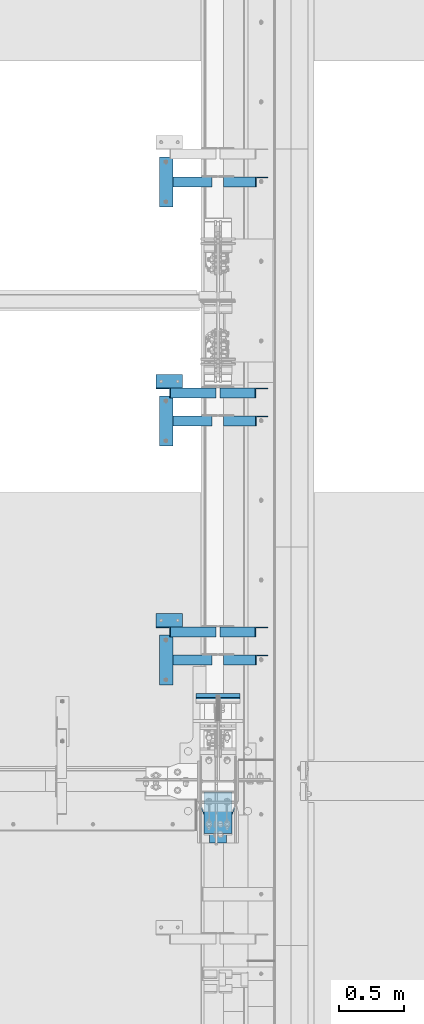
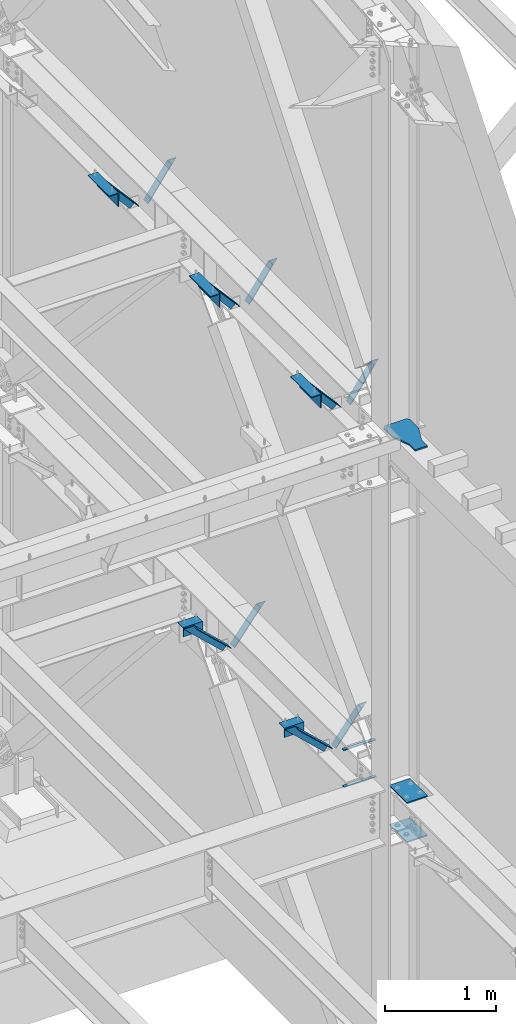
# One storey, part 844 of 1179: 10 beams, 10 members, 18 elements without a shape of their own.
"""IFC2X3 building model written with IfcOpenShell, lengths in millimetres."""

from ifc_helpers import new_model, si_unit, frame, origin_with_axes, place, context, subcontext, project, spatial, faceted_brep, material, type_object, element, aggregate, save


model = new_model("IFC2X3")

# Units and contexts
model_context = context("Model", 3, precision=1e-05, world=origin_with_axes())
body_context = subcontext(model_context, "Body", "Model", "MODEL_VIEW")
ifc_project = project(units=[si_unit("LENGTHUNIT", "METRE", prefix="MILLI"), si_unit("AREAUNIT", "SQUARE_METRE"), si_unit("VOLUMEUNIT", "CUBIC_METRE"), si_unit("MASSUNIT", "GRAM", prefix="KILO"), si_unit("TIMEUNIT", "SECOND"), si_unit("PLANEANGLEUNIT", "RADIAN"), si_unit("SOLIDANGLEUNIT", "STERADIAN"), si_unit("THERMODYNAMICTEMPERATUREUNIT", "DEGREE_CELSIUS"), si_unit("LUMINOUSINTENSITYUNIT", "LUMEN")], contexts=[model_context])

# Site, building, storey
site_placement = place(None, origin_with_axes())
site = spatial("IfcSite", under=ifc_project, at=site_placement, CompositionType="ELEMENT")
building_placement = place(site_placement, origin_with_axes())
building = spatial("IfcBuilding", under=site, at=building_placement, Name="Undefined", CompositionType="ELEMENT")
storey_placement = place(building_placement, origin_with_axes())
storey = spatial("IfcBuildingStorey", under=building, at=storey_placement, Name="Undefined", CompositionType="ELEMENT", Elevation=0.0)

# Assembly, beam
assembly_1_placement = place(storey_placement, origin_with_axes())
assembly_1 = element("IfcElementAssembly", 1, at=assembly_1_placement, inside=storey, Name="ANGLE", AssemblyPlace="NOTDEFINED", PredefinedType="RIGID_FRAME")
ifc_material_1 = material(Name="STEEL/A36")
beam_type_1 = type_object("IfcBeamType", Name="L6X4X5/16", PredefinedType="NOTDEFINED")
beam_1_placement = place(assembly_1_placement, frame((23910.8411671176, 31444.5838232686, 7937.5), z_axis=(0.0, 0.0, -1.0), x_axis=(0.0, 1.0, 0.0)))
beam_1 = element("IfcBeam", 2, at=beam_1_placement, type_object=beam_type_1, material=ifc_material_1, Name="ANGLE", ObjectType="L6X4X5/16", context=body_context, shape_type="Brep", body=[
    faceted_brep([(0.0, 50.8000000000029, -76.1999999999998), (0.0, 50.8000000000029, 76.1999999999998), (381.0, 50.7999999999993, 76.1999999999998), (381.0, 50.7999999999993, -76.1999999999998), (0.0, 42.8624999999993, 76.1999999999998), (381.0, 42.8624999999993, 76.1999999999998), (0.0, 42.8624999999993, -68.2624999999998), (381.0, 42.8624999999993, -68.2624999999998), (0.0, -50.7999999999993, -68.2624999999998), (381.0, -50.7999999999993, -68.2624999999998), (0.0, -50.8000000000029, -76.1999999999998), (381.0, -50.7999999999993, -76.1999999999998)], [[[0, 1, 2, 3]], [[1, 4, 5, 2]], [[4, 6, 7, 5]], [[6, 8, 9, 7]], [[8, 10, 11, 9]], [[10, 0, 3, 11]], [[5, 7, 9, 11, 3, 2]], [[10, 8, 6, 4, 1, 0]]]),
])
aggregate(assembly_1, [beam_1])

assembly_2_placement = place(storey_placement, origin_with_axes())
assembly_2 = element("IfcElementAssembly", 3, at=assembly_2_placement, inside=storey, Name="ANGLE", AssemblyPlace="NOTDEFINED", PredefinedType="RIGID_FRAME")
beam_2_placement = place(assembly_2_placement, frame((23910.8411671176, 29615.7838232686, 7937.5), z_axis=(0.0, 0.0, -1.0), x_axis=(0.0, 1.0, 0.0)))
beam_2 = element("IfcBeam", 4, at=beam_2_placement, type_object=beam_type_1, material=ifc_material_1, Name="ANGLE", ObjectType="L6X4X5/16", context=body_context, shape_type="Brep", body=[
    faceted_brep([(0.0, 50.8000000000029, -76.1999999999998), (0.0, 50.8000000000029, 76.1999999999998), (381.0, 50.7999999999993, 76.1999999999998), (381.0, 50.7999999999993, -76.1999999999998), (0.0, 42.8624999999993, 76.1999999999998), (381.0, 42.8624999999993, 76.1999999999998), (0.0, 42.8624999999993, -68.2624999999998), (381.0, 42.8624999999993, -68.2624999999998), (0.0, -50.7999999999993, -68.2624999999998), (381.0, -50.7999999999993, -68.2624999999998), (0.0, -50.8000000000029, -76.1999999999998), (381.0, -50.7999999999993, -76.1999999999998)], [[[0, 1, 2, 3]], [[1, 4, 5, 2]], [[4, 6, 7, 5]], [[6, 8, 9, 7]], [[8, 10, 11, 9]], [[10, 0, 3, 11]], [[5, 7, 9, 11, 3, 2]], [[10, 8, 6, 4, 1, 0]]]),
])
aggregate(assembly_2, [beam_2])

assembly_3_placement = place(storey_placement, origin_with_axes())
assembly_3 = element("IfcElementAssembly", 5, at=assembly_3_placement, inside=storey, Name="ANGLE", AssemblyPlace="NOTDEFINED", PredefinedType="RIGID_FRAME")
beam_3_placement = place(assembly_3_placement, frame((23910.8411671176, 27786.9838232686, 7937.5), z_axis=(0.0, 0.0, -1.0), x_axis=(0.0, 1.0, 0.0)))
beam_3 = element("IfcBeam", 6, at=beam_3_placement, type_object=beam_type_1, material=ifc_material_1, Name="ANGLE", ObjectType="L6X4X5/16", context=body_context, shape_type="Brep", body=[
    faceted_brep([(0.0, 50.8000000000029, -76.1999999999998), (0.0, 50.8000000000029, 76.1999999999998), (381.0, 50.7999999999993, 76.1999999999998), (381.0, 50.7999999999993, -76.1999999999998), (0.0, 42.8624999999993, 76.1999999999998), (381.0, 42.8624999999993, 76.1999999999998), (0.0, 42.8624999999993, -68.2624999999998), (381.0, 42.8624999999993, -68.2624999999998), (0.0, -50.7999999999993, -68.2624999999998), (381.0, -50.7999999999993, -68.2624999999998), (0.0, -50.8000000000029, -76.1999999999998), (381.0, -50.7999999999993, -76.1999999999998)], [[[0, 1, 2, 3]], [[1, 4, 5, 2]], [[4, 6, 7, 5]], [[6, 8, 9, 7]], [[8, 10, 11, 9]], [[10, 0, 3, 11]], [[5, 7, 9, 11, 3, 2]], [[10, 8, 6, 4, 1, 0]]]),
])
aggregate(assembly_3, [beam_3])

# Assembly, member
assembly_4_placement = place(storey_placement, origin_with_axes())
assembly_4 = element("IfcElementAssembly", 7, at=assembly_4_placement, inside=storey, Name="ANGLE", AssemblyPlace="NOTDEFINED", PredefinedType="RIGID_FRAME")
member_type = type_object("IfcMemberType", Name="L3X3X1/4", PredefinedType="NOTDEFINED")
member_1_placement = place(assembly_4_placement, frame((23812.1988269993, 31635.0838232686, 8126.5003839724), z_axis=(0.0, -1.0, 0.0), x_axis=(0.658094639765331, 0.0, -0.752935219731512)))
member_1 = element("IfcMember", 8, at=member_1_placement, type_object=member_type, material=ifc_material_1, Name="ANGLE", ObjectType="L3X3X1/4", context=body_context, shape_type="Brep", body=[
    faceted_brep([(183.619860552442, 38.1000000000859, -38.0999999999985), (183.619860784022, 38.1000000000822, 38.0999999999985), (639.062001231554, 38.1000000003442, 38.0999999999985), (639.062001231554, 38.1000000003442, -38.0999999999985), (190.88498399944, 31.7500000000909, 38.0999999999985), (639.062001231561, 31.7500000003529, 38.0999999999985), (190.884983787158, 31.7500000000873, -31.75), (639.062001231561, 31.7500000003529, -31.75), (270.801339156757, -38.0999999998203, -31.75), (639.062001231592, -38.0999999996056, -31.75), (270.801339137461, -38.0999999998203, -38.0999999999985), (639.062001231592, -38.0999999996056, -38.0999999999985)], [[[0, 1, 2, 3]], [[1, 4, 5, 2]], [[4, 6, 7, 5]], [[6, 8, 9, 7]], [[8, 10, 11, 9]], [[10, 0, 3, 11]], [[5, 7, 9, 11, 3, 2]], [[10, 8, 6, 4, 1, 0]]]),
])
aggregate(assembly_4, [member_1])

assembly_5_placement = place(storey_placement, origin_with_axes())
assembly_5 = element("IfcElementAssembly", 9, at=assembly_5_placement, inside=storey, Name="ANGLE", AssemblyPlace="NOTDEFINED", PredefinedType="RIGID_FRAME")
member_2_placement = place(assembly_5_placement, frame((24381.7111526842, 31635.0838233245, 7641.69043096418), z_axis=(0.0, -1.0, 0.0), x_axis=(0.573795345766208, 0.0, 0.818998718666298)))
member_2 = element("IfcMember", 10, at=member_2_placement, type_object=member_type, material=ifc_material_1, Name="ANGLE", ObjectType="L3X3X1/4", context=body_context, shape_type="Brep", body=[
    faceted_brep([(0.0, 38.0999999999985, -38.0999999999999), (0.0, 38.0999999999985, 38.0999999999999), (427.531758723813, 38.100000000517, 38.0999999999985), (427.531758723813, 38.100000000517, -38.0999999999985), (0.0, 31.75, 38.1000000000004), (431.980606125526, 31.7500000005184, 38.0999999999985), (0.0, 31.75, -31.75), (431.980606125526, 31.7500000005184, -31.75), (0.0, -38.0999999999985, -31.75), (480.917927544382, -38.0999999994783, -31.75), (0.0, -38.0999999999985, -38.0999999999999), (480.917927544382, -38.0999999994783, -38.0999999999985)], [[[0, 1, 2, 3]], [[1, 4, 5, 2]], [[4, 6, 7, 5]], [[6, 8, 9, 7]], [[8, 10, 11, 9]], [[10, 0, 3, 11]], [[5, 7, 9, 11, 3, 2]], [[10, 8, 6, 4, 1, 0]]]),
])
aggregate(assembly_5, [member_2])

assembly_6_placement = place(storey_placement, origin_with_axes())
assembly_6 = element("IfcElementAssembly", 11, at=assembly_6_placement, inside=storey, Name="ANGLE", AssemblyPlace="NOTDEFINED", PredefinedType="RIGID_FRAME")
member_3_placement = place(assembly_6_placement, frame((23812.1988269993, 29806.2838232686, 8126.5003839724), z_axis=(0.0, -1.0, 0.0), x_axis=(0.658094639765331, 0.0, -0.752935219731512)))
member_3 = element("IfcMember", 12, at=member_3_placement, type_object=member_type, material=ifc_material_1, Name="ANGLE", ObjectType="L3X3X1/4", context=body_context, shape_type="Brep", body=[
    faceted_brep([(183.619860552442, 38.1000000000859, -38.0999999999985), (183.619860784022, 38.1000000000822, 38.0999999999985), (639.062001231554, 38.1000000003442, 38.0999999999985), (639.062001231554, 38.1000000003442, -38.0999999999985), (190.88498399944, 31.7500000000909, 38.0999999999985), (639.062001231561, 31.7500000003529, 38.0999999999985), (190.884983787158, 31.7500000000873, -31.75), (639.062001231561, 31.7500000003529, -31.75), (270.801339156757, -38.0999999998203, -31.75), (639.062001231592, -38.0999999996056, -31.75), (270.801339137461, -38.0999999998203, -38.0999999999985), (639.062001231592, -38.0999999996056, -38.0999999999985)], [[[0, 1, 2, 3]], [[1, 4, 5, 2]], [[4, 6, 7, 5]], [[6, 8, 9, 7]], [[8, 10, 11, 9]], [[10, 0, 3, 11]], [[5, 7, 9, 11, 3, 2]], [[10, 8, 6, 4, 1, 0]]]),
])
aggregate(assembly_6, [member_3])

assembly_7_placement = place(storey_placement, origin_with_axes())
assembly_7 = element("IfcElementAssembly", 13, at=assembly_7_placement, inside=storey, Name="ANGLE", AssemblyPlace="NOTDEFINED", PredefinedType="RIGID_FRAME")
member_4_placement = place(assembly_7_placement, frame((24381.7111526842, 29806.2838233245, 7641.69043096418), z_axis=(0.0, -1.0, 0.0), x_axis=(0.573795345766208, 0.0, 0.818998718666298)))
member_4 = element("IfcMember", 14, at=member_4_placement, type_object=member_type, material=ifc_material_1, Name="ANGLE", ObjectType="L3X3X1/4", context=body_context, shape_type="Brep", body=[
    faceted_brep([(0.0, 38.0999999999985, -38.0999999999999), (0.0, 38.0999999999985, 38.0999999999999), (427.531758723813, 38.100000000517, 38.0999999999985), (427.531758723813, 38.100000000517, -38.0999999999985), (0.0, 31.75, 38.1000000000004), (431.980606125526, 31.7500000005184, 38.0999999999985), (0.0, 31.75, -31.75), (431.980606125526, 31.7500000005184, -31.75), (0.0, -38.0999999999985, -31.75), (480.917927544382, -38.0999999994783, -31.75), (0.0, -38.0999999999985, -38.0999999999999), (480.917927544382, -38.0999999994783, -38.0999999999985)], [[[0, 1, 2, 3]], [[1, 4, 5, 2]], [[4, 6, 7, 5]], [[6, 8, 9, 7]], [[8, 10, 11, 9]], [[10, 0, 3, 11]], [[5, 7, 9, 11, 3, 2]], [[10, 8, 6, 4, 1, 0]]]),
])
aggregate(assembly_7, [member_4])

assembly_8_placement = place(storey_placement, origin_with_axes())
assembly_8 = element("IfcElementAssembly", 15, at=assembly_8_placement, inside=storey, Name="ANGLE", AssemblyPlace="NOTDEFINED", PredefinedType="RIGID_FRAME")
member_5_placement = place(assembly_8_placement, frame((23812.1988269993, 27977.4838232686, 8126.5003839724), z_axis=(0.0, -1.0, 0.0), x_axis=(0.658094639765331, 0.0, -0.752935219731512)))
member_5 = element("IfcMember", 16, at=member_5_placement, type_object=member_type, material=ifc_material_1, Name="ANGLE", ObjectType="L3X3X1/4", context=body_context, shape_type="Brep", body=[
    faceted_brep([(183.619860552442, 38.1000000000859, -38.0999999999985), (183.619860784022, 38.1000000000822, 38.0999999999985), (639.062001231554, 38.1000000003442, 38.0999999999985), (639.062001231554, 38.1000000003442, -38.0999999999985), (190.88498399944, 31.7500000000909, 38.0999999999985), (639.062001231561, 31.7500000003529, 38.0999999999985), (190.884983787158, 31.7500000000873, -31.75), (639.062001231561, 31.7500000003529, -31.75), (270.801339156757, -38.0999999998203, -31.75), (639.062001231592, -38.0999999996056, -31.75), (270.801339137461, -38.0999999998203, -38.0999999999985), (639.062001231592, -38.0999999996056, -38.0999999999985)], [[[0, 1, 2, 3]], [[1, 4, 5, 2]], [[4, 6, 7, 5]], [[6, 8, 9, 7]], [[8, 10, 11, 9]], [[10, 0, 3, 11]], [[5, 7, 9, 11, 3, 2]], [[10, 8, 6, 4, 1, 0]]]),
])
aggregate(assembly_8, [member_5])

assembly_9_placement = place(storey_placement, origin_with_axes())
assembly_9 = element("IfcElementAssembly", 17, at=assembly_9_placement, inside=storey, Name="ANGLE", AssemblyPlace="NOTDEFINED", PredefinedType="RIGID_FRAME")
member_6_placement = place(assembly_9_placement, frame((24381.7111526842, 27977.4838233245, 7641.69043096418), z_axis=(0.0, -1.0, 0.0), x_axis=(0.573795345766208, 0.0, 0.818998718666298)))
member_6 = element("IfcMember", 18, at=member_6_placement, type_object=member_type, material=ifc_material_1, Name="ANGLE", ObjectType="L3X3X1/4", context=body_context, shape_type="Brep", body=[
    faceted_brep([(0.0, 38.0999999999985, -38.0999999999999), (0.0, 38.0999999999985, 38.0999999999999), (427.531758723813, 38.100000000517, 38.0999999999985), (427.531758723813, 38.100000000517, -38.0999999999985), (0.0, 31.75, 38.1000000000004), (431.980606125526, 31.7500000005184, 38.0999999999985), (0.0, 31.75, -31.75), (431.980606125526, 31.7500000005184, -31.75), (0.0, -38.0999999999985, -31.75), (480.917927544382, -38.0999999994783, -31.75), (0.0, -38.0999999999985, -38.0999999999999), (480.917927544382, -38.0999999994783, -38.0999999999985)], [[[0, 1, 2, 3]], [[1, 4, 5, 2]], [[4, 6, 7, 5]], [[6, 8, 9, 7]], [[8, 10, 11, 9]], [[10, 0, 3, 11]], [[5, 7, 9, 11, 3, 2]], [[10, 8, 6, 4, 1, 0]]]),
])
aggregate(assembly_9, [member_6])

assembly_10_placement = place(storey_placement, origin_with_axes())
assembly_10 = element("IfcElementAssembly", 19, at=assembly_10_placement, inside=storey, Name="ANGLE", AssemblyPlace="NOTDEFINED", PredefinedType="RIGID_FRAME")
member_7_placement = place(assembly_10_placement, frame((23812.1150890972, 30021.8916453824, 4162.88757791506), z_axis=(0.0, -1.0, 0.0), x_axis=(0.729484494811633, 0.0, -0.683997347823379)))
member_7 = element("IfcMember", 20, at=member_7_placement, type_object=member_type, material=ifc_material_1, Name="ANGLE", ObjectType="L3X3X1/4", context=body_context, shape_type="Brep", body=[
    faceted_brep([(148.072119708857, 38.1000000000204, -38.0999999999985), (148.072119708857, 38.1000000000204, 38.0999999999985), (623.824460863128, 38.1000000000349, 38.0999999999985), (623.824460863128, 38.1000000000349, -38.0999999999985), (141.299832423247, 31.7500000000182, 38.0999999999985), (623.824460863128, 31.7500000000291, 38.0999999999985), (141.299832423247, 31.7500000000182, -31.75), (623.824460863128, 31.7500000000291, -31.75), (66.8046722815307, -38.1000000000095, -31.75), (623.824460863132, -38.0999999999913, -31.75), (66.8046722815307, -38.1000000000095, -38.0999999999985), (623.824460863132, -38.0999999999913, -38.0999999999985)], [[[0, 1, 2, 3]], [[1, 4, 5, 2]], [[4, 6, 7, 5]], [[6, 8, 9, 7]], [[8, 10, 11, 9]], [[10, 0, 3, 11]], [[5, 7, 9, 11, 3, 2]], [[10, 8, 6, 4, 1, 0]]]),
])
aggregate(assembly_10, [member_7])

assembly_11_placement = place(storey_placement, origin_with_axes())
assembly_11 = element("IfcElementAssembly", 21, at=assembly_11_placement, inside=storey, Name="ANGLE", AssemblyPlace="NOTDEFINED", PredefinedType="RIGID_FRAME")
member_8_placement = place(assembly_11_placement, frame((23812.1150890972, 28193.0916453824, 4162.88757791506), z_axis=(0.0, -1.0, 0.0), x_axis=(0.729484494811633, 0.0, -0.683997347823379)))
member_8 = element("IfcMember", 22, at=member_8_placement, type_object=member_type, material=ifc_material_1, Name="ANGLE", ObjectType="L3X3X1/4", context=body_context, shape_type="Brep", body=[
    faceted_brep([(148.072119708857, 38.1000000000204, -38.0999999999985), (148.072119708857, 38.1000000000204, 38.0999999999985), (623.824460863128, 38.1000000000349, 38.0999999999985), (623.824460863128, 38.1000000000349, -38.0999999999985), (141.299832423247, 31.7500000000182, 38.0999999999985), (623.824460863128, 31.7500000000291, 38.0999999999985), (141.299832423247, 31.7500000000182, -31.75), (623.824460863128, 31.7500000000291, -31.75), (66.8046722815307, -38.1000000000095, -31.75), (623.824460863132, -38.0999999999913, -31.75), (66.8046722815307, -38.1000000000095, -38.0999999999985), (623.824460863132, -38.0999999999913, -38.0999999999985)], [[[0, 1, 2, 3]], [[1, 4, 5, 2]], [[4, 6, 7, 5]], [[6, 8, 9, 7]], [[8, 10, 11, 9]], [[10, 0, 3, 11]], [[5, 7, 9, 11, 3, 2]], [[10, 8, 6, 4, 1, 0]]]),
])
aggregate(assembly_11, [member_8])

assembly_12_placement = place(storey_placement, origin_with_axes())
assembly_12 = element("IfcElementAssembly", 23, at=assembly_12_placement, inside=storey, Name="ANGLE", AssemblyPlace="NOTDEFINED", PredefinedType="RIGID_FRAME")
member_9_placement = place(assembly_12_placement, frame((24352.3014298031, 30021.8916453824, 3731.6636484264), z_axis=(0.0, -1.0, 0.0), x_axis=(0.614083067285056, 0.0, 0.789241399366365)))
member_9 = element("IfcMember", 24, at=member_9_placement, type_object=member_type, material=ifc_material_1, Name="ANGLE", ObjectType="L3X3X1/4", context=body_context, shape_type="Brep", body=[
    faceted_brep([(0.0, 38.0999999999985, -38.0999999999999), (0.0, 38.0999999999985, 38.0999999999999), (439.713105507173, 38.1000000000386, 38.0999999999985), (439.713105507173, 38.1000000000386, -38.0999999999985), (0.0, 31.75, 38.1000000000004), (444.653834009747, 31.7500000000473, 38.0999999999985), (0.0, 31.75, -31.75), (444.653834009747, 31.7500000000473, -31.75), (0.0, -38.0999999999985, -31.75), (499.001847538042, -38.0999999998749, -31.75), (0.0, -38.0999999999985, -38.0999999999999), (499.001847538042, -38.0999999998749, -38.0999999999985)], [[[0, 1, 2, 3]], [[1, 4, 5, 2]], [[4, 6, 7, 5]], [[6, 8, 9, 7]], [[8, 10, 11, 9]], [[10, 0, 3, 11]], [[5, 7, 9, 11, 3, 2]], [[10, 8, 6, 4, 1, 0]]]),
])
aggregate(assembly_12, [member_9])

assembly_13_placement = place(storey_placement, origin_with_axes())
assembly_13 = element("IfcElementAssembly", 25, at=assembly_13_placement, inside=storey, Name="ANGLE", AssemblyPlace="NOTDEFINED", PredefinedType="RIGID_FRAME")
member_10_placement = place(assembly_13_placement, frame((24352.3014298031, 28193.0916453824, 3731.6636484264), z_axis=(0.0, -1.0, 0.0), x_axis=(0.614083067285056, 0.0, 0.789241399366365)))
member_10 = element("IfcMember", 26, at=member_10_placement, type_object=member_type, material=ifc_material_1, Name="ANGLE", ObjectType="L3X3X1/4", context=body_context, shape_type="Brep", body=[
    faceted_brep([(0.0, 38.0999999999985, -38.0999999999999), (0.0, 38.0999999999985, 38.0999999999999), (439.713105507173, 38.1000000000386, 38.0999999999985), (439.713105507173, 38.1000000000386, -38.0999999999985), (0.0, 31.75, 38.1000000000004), (444.653834009747, 31.7500000000473, 38.0999999999985), (0.0, 31.75, -31.75), (444.653834009747, 31.7500000000473, -31.75), (0.0, -38.0999999999985, -31.75), (499.001847538042, -38.0999999998749, -31.75), (0.0, -38.0999999999985, -38.0999999999999), (499.001847538042, -38.0999999998749, -38.0999999999985)], [[[0, 1, 2, 3]], [[1, 4, 5, 2]], [[4, 6, 7, 5]], [[6, 8, 9, 7]], [[8, 10, 11, 9]], [[10, 0, 3, 11]], [[5, 7, 9, 11, 3, 2]], [[10, 8, 6, 4, 1, 0]]]),
])
aggregate(assembly_13, [member_10])

# Assembly, beams
assembly_14_placement = place(storey_placement, origin_with_axes())
assembly_14 = element("IfcElementAssembly", 27, at=assembly_14_placement, inside=storey, Name="BEAM", AssemblyPlace="NOTDEFINED", PredefinedType="RIGID_FRAME")
ifc_material_2 = material(Name="STEEL/A572-GR.50")
beam_type_2 = type_object("IfcBeamType", PredefinedType="NOTDEFINED")
beam_4_placement = place(assembly_14_placement, frame((24307.8000366209, 27711.6209039934, 3678.2375), z_axis=(-1.0, 0.0, 0.0), x_axis=(0.0, -1.0, 0.0)))
beam_4 = element("IfcBeam", 28, at=beam_4_placement, type_object=beam_type_2, material=ifc_material_2, Name="PLATE", context=body_context, shape_type="Brep", body=[
    faceted_brep([(0.0, 4.76249999999982, -168.275000000001), (0.0, 4.76250000000073, 168.275), (31.75, 4.76249999999982, 168.275000000001), (31.75, 4.76249999999982, -168.275000000001), (0.0, -4.76250000000073, 168.275), (31.75, -4.76249999999982, 168.275000000001), (0.0, -4.76249999999982, -168.275000000001), (31.75, -4.76249999999982, -168.275000000001)], [[[0, 1, 2, 3]], [[1, 4, 5, 2]], [[4, 6, 7, 5]], [[6, 0, 3, 7]], [[5, 7, 3, 2]], [[6, 4, 1, 0]]]),
])
beam_5_placement = place(assembly_14_placement, frame((24307.8000366209, 27722.733001131, 4077.8905), z_axis=(-1.0, 0.0, 0.0), x_axis=(0.0, -1.0, 0.0)))
beam_5 = element("IfcBeam", 29, at=beam_5_placement, type_object=beam_type_2, material=ifc_material_2, Name="PLATE", context=body_context, shape_type="Brep", body=[
    faceted_brep([(0.0, 4.76249999999982, -168.275000000001), (0.0, 4.76250000000073, 168.275), (31.75, 4.76249999999982, 168.275000000001), (31.75, 4.76249999999982, -168.275000000001), (0.0, -4.76250000000073, 168.275), (31.75, -4.76249999999982, 168.275000000001), (0.0, -4.76249999999982, -168.275000000001), (31.75, -4.76249999999982, -168.275000000001)], [[[0, 1, 2, 3]], [[1, 4, 5, 2]], [[4, 6, 7, 5]], [[6, 0, 3, 7]], [[5, 7, 3, 2]], [[6, 4, 1, 0]]]),
])
aggregate(assembly_14, [beam_4, beam_5])

assembly_15_placement = place(storey_placement, origin_with_axes())
assembly_15 = element("IfcElementAssembly", 30, at=assembly_15_placement, inside=storey, Name="COLUMN", AssemblyPlace="NOTDEFINED", PredefinedType="RIGID_FRAME")
beam_type_3 = type_object("IfcBeamType", PredefinedType="NOTDEFINED")
beam_6_placement = place(assembly_15_placement, frame((24307.8, 26968.4499999468, 3676.65), z_axis=(-1.0, 0.0, 0.0), x_axis=(0.0, -1.0, 0.0)))
beam_6 = element("IfcBeam", 31, at=beam_6_placement, type_object=beam_type_3, material=ifc_material_2, Name="PLATE", context=body_context, shape_type="Brep", body=[
    faceted_brep([(0.0, 6.35000000000036, -107.949999999997), (0.0, 6.35000000000036, 107.949999999997), (317.5, 6.35000000000036, 107.949999999997), (317.5, 6.35000000000036, -107.949999999997), (0.0, -6.35000000000036, 107.949999999997), (317.5, -6.35000000000036, 107.949999999997), (0.0, -6.35000000000036, -107.949999999997), (317.5, -6.35000000000036, -107.949999999997)], [[[0, 1, 2, 3]], [[1, 4, 5, 2]], [[4, 6, 7, 5]], [[6, 0, 3, 7]], [[5, 7, 3, 2]], [[6, 4, 1, 0]]]),
])
beam_7_placement = place(assembly_15_placement, frame((24307.8, 26968.4499999468, 4108.44999999953), z_axis=(-1.0, 0.0, 0.0), x_axis=(0.0, -1.0, 0.0)))
beam_7 = element("IfcBeam", 32, at=beam_7_placement, type_object=beam_type_3, material=ifc_material_2, Name="PLATE", context=body_context, shape_type="Brep", body=[
    faceted_brep([(0.0, 6.35000000000036, -107.949999999997), (0.0, 6.35000000000036, 107.949999999997), (317.5, 6.35000000000036, 107.949999999997), (317.5, 6.35000000000036, -107.949999999997), (0.0, -6.35000000000036, 107.949999999997), (317.5, -6.35000000000036, 107.949999999997), (0.0, -6.35000000000036, -107.949999999997), (317.5, -6.35000000000036, -107.949999999997)], [[[0, 1, 2, 3]], [[1, 4, 5, 2]], [[4, 6, 7, 5]], [[6, 0, 3, 7]], [[5, 7, 3, 2]], [[6, 4, 1, 0]]]),
])
aggregate(assembly_15, [beam_6, beam_7])

# Assembly, beam
assembly_16_placement = place(storey_placement, origin_with_axes())
assembly_16 = element("IfcElementAssembly", 33, at=assembly_16_placement, inside=storey, Name="ANGLE", AssemblyPlace="NOTDEFINED", PredefinedType="RIGID_FRAME")
beam_type_4 = type_object("IfcBeamType", Name="L4X4X1/4", PredefinedType="NOTDEFINED")
beam_8_placement = place(assembly_16_placement, frame((23834.8036446584, 30110.7916453824, 4051.3), z_axis=(0.0, 0.0, -1.0), x_axis=(1.0, 0.0, 0.0)))
beam_8 = element("IfcBeam", 34, at=beam_8_placement, type_object=beam_type_4, material=ifc_material_1, Name="ANGLE", ObjectType="L4X4X1/4", context=body_context, shape_type="Brep", body=[
    faceted_brep([(1.90993887372315e-11, 50.8000000000002, -50.8000000000002), (1.90993887372315e-11, 50.8000000000002, 50.8000000000002), (203.200000000001, 50.7999999999993, 50.8000000000002), (203.200000000001, 50.7999999999993, -50.8000000000002), (0.0, 44.4500000000007, 50.8000000000002), (203.200000000001, 44.4500000000007, 50.8000000000002), (0.0, 44.4500000000007, -44.4499999999998), (203.200000000001, 44.4500000000007, -44.4499999999998), (0.0, -50.7999999999993, -44.4499999999998), (203.200000000001, -50.7999999999993, -44.4499999999998), (-1.81898940354586e-11, -50.7999999999997, -50.8000000000002), (203.200000000001, -50.7999999999993, -50.8000000000002)], [[[0, 1, 2, 3]], [[1, 4, 5, 2]], [[4, 6, 7, 5]], [[6, 8, 9, 7]], [[8, 10, 11, 9]], [[10, 0, 3, 11]], [[5, 7, 9, 11, 3, 2]], [[10, 8, 6, 4, 1, 0]]]),
])
aggregate(assembly_16, [beam_8])

assembly_17_placement = place(storey_placement, origin_with_axes())
assembly_17 = element("IfcElementAssembly", 35, at=assembly_17_placement, inside=storey, Name="ANGLE", AssemblyPlace="NOTDEFINED", PredefinedType="RIGID_FRAME")
beam_9_placement = place(assembly_17_placement, frame((23834.8036446584, 28281.9916453824, 4051.3), z_axis=(0.0, 0.0, -1.0), x_axis=(1.0, 0.0, 0.0)))
beam_9 = element("IfcBeam", 36, at=beam_9_placement, type_object=beam_type_4, material=ifc_material_1, Name="ANGLE", ObjectType="L4X4X1/4", context=body_context, shape_type="Brep", body=[
    faceted_brep([(1.90993887372315e-11, 50.8000000000002, -50.8000000000002), (1.90993887372315e-11, 50.8000000000002, 50.8000000000002), (203.200000000001, 50.7999999999993, 50.8000000000002), (203.200000000001, 50.7999999999993, -50.8000000000002), (0.0, 44.4500000000007, 50.8000000000002), (203.200000000001, 44.4500000000007, 50.8000000000002), (0.0, 44.4500000000007, -44.4499999999998), (203.200000000001, 44.4500000000007, -44.4499999999998), (0.0, -50.7999999999993, -44.4499999999998), (203.200000000001, -50.7999999999993, -44.4499999999998), (-1.81898940354586e-11, -50.7999999999997, -50.8000000000002), (203.200000000001, -50.7999999999993, -50.8000000000002)], [[[0, 1, 2, 3]], [[1, 4, 5, 2]], [[4, 6, 7, 5]], [[6, 8, 9, 7]], [[8, 10, 11, 9]], [[10, 0, 3, 11]], [[5, 7, 9, 11, 3, 2]], [[10, 8, 6, 4, 1, 0]]]),
])
aggregate(assembly_17, [beam_9])

assembly_18_placement = place(storey_placement, origin_with_axes())
assembly_18 = element("IfcElementAssembly", 37, at=assembly_18_placement, inside=storey, Name="PLATE", AssemblyPlace="NOTDEFINED", PredefinedType="RIGID_FRAME")
beam_type_5 = type_object("IfcBeamType", PredefinedType="NOTDEFINED")
beam_10_placement = place(assembly_18_placement, frame((24307.8, 26579.5125, 8023.22500000912), z_axis=(1.0, 0.0, 0.0), x_axis=(0.0, 1.0, 0.0)))
beam_10 = element("IfcBeam", 38, at=beam_10_placement, type_object=beam_type_5, material=ifc_material_1, Name="PLATE", context=body_context, shape_type="Brep", body=[
    faceted_brep([(465.137499999997, -7.9375, -114.300000762945), (442.912499999999, -7.9375, -136.525000762944), (442.912500000006, 7.9375, -136.525000762944), (465.137500000004, 7.9375, -114.300000762945), (465.137500000004, 7.9375, 114.300000762938), (442.912500000006, 7.9375, 136.525000762937), (442.912499999999, -7.9375, 136.525000762937), (465.137499999997, -7.9375, 114.300000762938), (96.7084051981856, -7.9375, 63.4999984741225), (96.7084051981856, 7.9375, 63.4999984741225), (0.0, 7.9375, 63.5), (0.0, -7.9375, 63.5), (99.1209783650102, -7.9375, 63.6148350254298), (99.1209783650102, 7.9375, 63.6148350254298), (101.511736446291, -7.9375, 63.958306298744), (101.511736446291, 7.9375, 63.958306298744), (103.859061613901, -7.9375, 64.5273065415386), (103.859061613901, 7.9375, 64.5273065415386), (106.141728770905, -7.9375, 65.3166907123523), (106.141728770905, 7.9375, 65.3166907123523), (284.162490278406, -7.9375, 136.524999999998), (284.162490278406, 7.9375, 136.525000000001), (0.0, -7.9375, -63.5), (0.0, 7.9375, -63.5), (96.7084055018695, 7.9375, -63.5), (96.7084055018695, -7.9375, -63.5), (99.1209785229439, 7.9375, -63.6148365373992), (99.1209785229439, -7.9375, -63.6148365373992), (101.511736462435, 7.9375, -63.9583077692478), (101.511736462435, -7.9375, -63.9583077692478), (103.859061496114, 7.9375, -64.5273079437611), (103.859061496114, -7.9375, -64.5273079437611), (106.141728530831, 7.9375, -65.3166920207259), (106.141728530831, -7.9375, -65.3166920207259), (284.162502485447, -7.9375, -136.525001525879), (284.162502485447, 7.9375, -136.525000000001)], [[[0, 1, 2, 3]], [[4, 5, 6, 7]], [[8, 9, 10, 11]], [[12, 13, 9, 8]], [[14, 15, 13, 12]], [[16, 17, 15, 14]], [[18, 19, 17, 16]], [[20, 21, 19, 18]], [[22, 23, 24, 25]], [[25, 24, 26, 27]], [[27, 26, 28, 29]], [[29, 28, 30, 31]], [[31, 30, 32, 33]], [[34, 33, 32, 35]], [[34, 35, 2, 1]], [[4, 7, 0, 3]], [[7, 6, 20, 18, 16, 14, 12, 8, 11, 22, 25, 27, 29, 31, 33, 34, 1, 0]], [[22, 11, 10, 23]], [[35, 32, 30, 28, 26, 24, 23, 10, 9, 13, 15, 17, 19, 21, 5, 4, 3, 2]], [[21, 20, 6, 5]]]),
])
aggregate(assembly_18, [beam_10])

save(model, "model.ifc")
